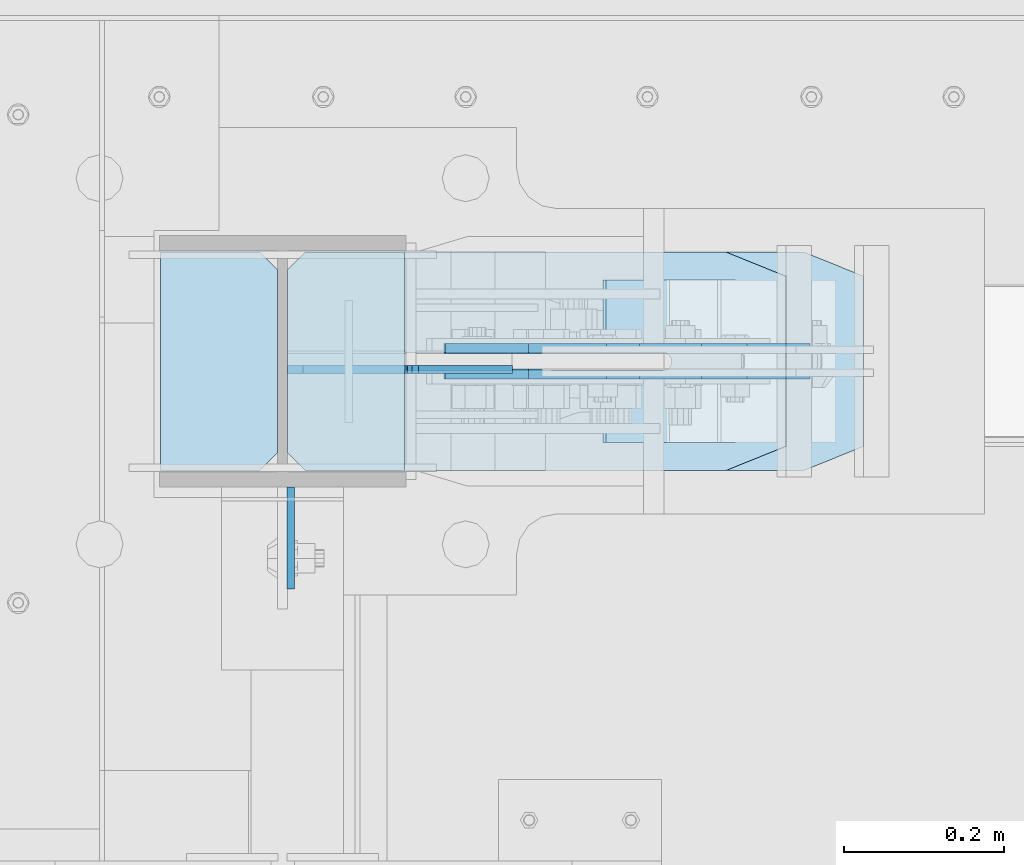
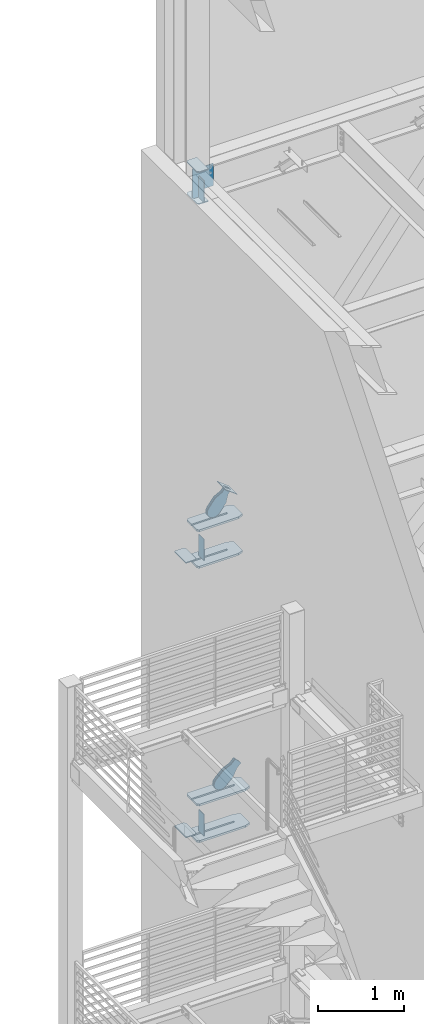
# One storey, part 1066 of 1179: 17 plates, 6 elements without a shape of their own.
"""IFC2X3 building model written with IfcOpenShell, lengths in millimetres."""

import ifcopenshell
import ifcopenshell.guid

model = None  # the IFC model being written
_history = None  # IfcOwnerHistory: only IFC2X3 demands one
_inside = {}  # id of a spatial element -> (the spatial element, [elements in it])
_under = {}  # id of a project, library or spatial element -> (it, [spatial elements below it])
_declared = {}  # id of a project -> (the project, [libraries it declares])
_typed = {}  # id of a type object -> (the type object, [elements of that type])
_made_of = {}  # id of a material, layer set ... -> (it, [elements and type objects made of it])


def new_model(schema):
    """Start an empty IFC model of exactly this schema.

    Asked for "IFC4X3", IfcOpenShell would pick the latest addendum, in which some entities
    have other attributes; the version numbers below select the first issue.
    IFC2X3 requires an IfcOwnerHistory on every rooted entity: one is made here for all.
    """
    global model, _history
    if schema == "IFC4X3":
        model = ifcopenshell.file(schema_version=(4, 3, 0, 0))
    else:
        model = ifcopenshell.file(schema=schema)
    _inside.clear()
    _under.clear()
    _declared.clear()
    _typed.clear()
    _made_of.clear()
    _history = None
    if model.schema == "IFC2X3":
        org = make("IfcOrganization", Name="unknown")
        user = make(
            "IfcPersonAndOrganization",
            ThePerson=make("IfcPerson", FamilyName="unknown"),
            TheOrganization=org,
        )
        app = make(
            "IfcApplication",
            ApplicationDeveloper=org,
            Version="unknown",
            ApplicationFullName="unknown",
            ApplicationIdentifier="unknown",
        )
        _history = make(
            "IfcOwnerHistory",
            OwningUser=user,
            OwningApplication=app,
            ChangeAction="ADDED",
            CreationDate=0,
        )
    return model


def make(cls, **values):
    """One entity of the class cls with the attributes given. An attribute that is None is left unset."""
    return model.create_entity(
        cls, **{name: value for name, value in values.items() if value is not None}
    )


def rooted(cls, **values):
    """An entity with a GlobalId (a new one), such as an element, a storey or a relation."""
    return make(cls, GlobalId=ifcopenshell.guid.new(), OwnerHistory=_history, **values)


def si_unit(unit_type, name, prefix=None):
    """IfcSIUnit, for example si_unit("LENGTHUNIT", "METRE", prefix="MILLI")."""
    return make("IfcSIUnit", UnitType=unit_type, Prefix=prefix, Name=name)


def assignment(units):
    """IfcUnitAssignment: the units of a project."""
    return None if units is None else make("IfcUnitAssignment", Units=units)


def point(xyz):
    """IfcCartesianPoint."""
    return None if xyz is None else make("IfcCartesianPoint", Coordinates=xyz)


def direction(xyz):
    """IfcDirection."""
    return None if xyz is None else make("IfcDirection", DirectionRatios=xyz)


def frame(location, z_axis=None, x_axis=None):
    """IfcAxis2Placement3D, a coordinate frame: its origin and axes. An axis left out is left unset."""
    return make(
        "IfcAxis2Placement3D",
        Location=point(location),
        Axis=direction(z_axis),
        RefDirection=direction(x_axis),
    )


def origin_with_axes():
    """The frame at (0, 0, 0) with the z axis (0, 0, 1) and the x axis (1, 0, 0) written out."""
    return frame((0.0, 0.0, 0.0), z_axis=(0.0, 0.0, 1.0), x_axis=(1.0, 0.0, 0.0))


def place(relative_to, where):
    """IfcLocalPlacement: puts the frame where relative to a parent placement (None: the world)."""
    return make(
        "IfcLocalPlacement", PlacementRelTo=relative_to, RelativePlacement=where
    )


def context(
    kind, dimensions, precision=None, world=None, true_north=None, identifier=None
):
    """IfcGeometricRepresentationContext, for example the 3D "Model" context."""
    return make(
        "IfcGeometricRepresentationContext",
        ContextIdentifier=identifier,
        ContextType=kind,
        CoordinateSpaceDimension=dimensions,
        Precision=precision,
        WorldCoordinateSystem=world,
        TrueNorth=true_north,
    )


def subcontext(parent, identifier, kind, view, scale=None):
    """IfcGeometricRepresentationSubContext, for example "Body" below "Model"."""
    return make(
        "IfcGeometricRepresentationSubContext",
        ContextIdentifier=identifier,
        ContextType=kind,
        ParentContext=parent,
        TargetScale=scale,
        TargetView=view,
    )


def project(units=None, contexts=None):
    """IfcProject with its units and contexts."""
    return rooted(
        "IfcProject",
        Name="project",
        RepresentationContexts=contexts,
        UnitsInContext=assignment(units),
    )


def spatial(cls, under=None, at=None, **own):
    """A site, building, storey or space (cls), placed at a placement, below another one or the project."""
    s = rooted(cls, ObjectPlacement=at, **own)
    if under is not None:
        _under.setdefault(under.id(), (under, []))[1].append(s)
    return s


def faces_of(points, faces, orient=None, outer=None):
    """IfcFace entities. A face is a list of loops; a loop is a list of indices into points, from 0.

    orient and outer hold one flag for each loop. By default every Orientation is true, the
    first loop of a face is its IfcFaceOuterBound and the others are IfcFaceBound.
    """
    made = []
    for i, loops in enumerate(faces):
        bounds = []
        for j, loop in enumerate(loops):
            is_outer = j == 0 if outer is None else outer[i][j]
            bounds.append(
                make(
                    "IfcFaceOuterBound" if is_outer else "IfcFaceBound",
                    Bound=make("IfcPolyLoop", Polygon=[points[k] for k in loop]),
                    Orientation=True if orient is None else orient[i][j],
                )
            )
        made.append(make("IfcFace", Bounds=bounds))
    return made


def faceted_brep(points, faces, orient=None, outer=None, voids=None):
    """IfcFacetedBrep: a solid bounded by flat faces; with voids (closed shells), ...WithVoids."""
    shared = [point(p) for p in points]
    hull = make("IfcClosedShell", CfsFaces=faces_of(shared, faces, orient, outer))
    if voids is None:
        return make("IfcFacetedBrep", Outer=hull)
    return make(
        "IfcFacetedBrepWithVoids",
        Outer=hull,
        Voids=[
            make(cls, CfsFaces=faces_of(shared, fs, o, b)) for cls, fs, o, b in voids
        ],
    )


def shape(context_of_items, identifier, shape_type, items):
    """IfcShapeRepresentation: the items that make up one representation, for example the "Body"."""
    return make(
        "IfcShapeRepresentation",
        ContextOfItems=context_of_items,
        RepresentationIdentifier=identifier,
        RepresentationType=shape_type,
        Items=items,
    )


def material(Name=None, Category=None):
    """IfcMaterial."""
    return make("IfcMaterial", Name=Name, Category=Category)


def made_of(thing, what):
    """Note that an element or type object is made of a material, layer set ...; save() writes the relation."""
    if what is not None:
        _made_of.setdefault(what.id(), (what, []))[1].append(thing)
    return thing


def type_object(cls, material=None, **own):
    """A type object (cls), such as IfcWallType, which elements share."""
    return made_of(rooted(cls, **own), material)


def element(
    cls,
    number,
    at=None,
    inside=None,
    cuts=None,
    type_object=None,
    material=None,
    context=None,
    identifier="Body",
    shape_type=None,
    held_by="IfcProductDefinitionShape",
    body=None,
    shapes=None,
    **own,
):
    """One element of the class cls, such as IfcWall. Its Tag is "e" and its number.

    at: its placement. inside: the storey or other place that contains it. cuts: it is an
    opening in that element (IfcRelVoidsElement). A single representation is given by context,
    identifier, shape_type and body (its items); several are given by shapes. held_by: the class
    of the entity that holds the representations. save() writes the other relations.
    """
    e = rooted(cls, Tag="e%d" % number, ObjectPlacement=at, **own)
    if body is not None:
        shapes = [shape(context, identifier, shape_type, body)]
    if shapes is not None:
        e.Representation = make(held_by, Representations=shapes)
    if inside is not None:
        _inside.setdefault(inside.id(), (inside, []))[1].append(e)
    if cuts is not None:
        rooted(
            "IfcRelVoidsElement", RelatingBuildingElement=cuts, RelatedOpeningElement=e
        )
    if type_object is not None:
        _typed.setdefault(type_object.id(), (type_object, []))[1].append(e)
    return made_of(e, material)


def aggregate(whole, parts):
    """IfcRelAggregates: a whole, such as a stair, and the parts it consists of."""
    return rooted("IfcRelAggregates", RelatingObject=whole, RelatedObjects=parts)


def save(model, path):
    """Write the relations noted so far, then the file.

    IfcRelAggregates (storeys below a building ...), IfcRelContainedInSpatialStructure (elements
    in a storey), IfcRelDefinesByType, IfcRelAssociatesMaterial and IfcRelDeclares: one each for
    every whole, place, type object, material and project.
    """
    for whole, parts in _under.values():
        aggregate(whole, parts)
    for where, things in _inside.values():
        rooted(
            "IfcRelContainedInSpatialStructure",
            RelatedElements=things,
            RelatingStructure=where,
        )
    for kind, things in _typed.values():
        rooted("IfcRelDefinesByType", RelatedObjects=things, RelatingType=kind)
    for what, things in _made_of.values():
        rooted("IfcRelAssociatesMaterial", RelatedObjects=things, RelatingMaterial=what)
    for by, libraries in _declared.values():
        rooted("IfcRelDeclares", RelatingContext=by, RelatedDefinitions=libraries)
    model.write(path)


model = new_model("IFC2X3")

# Units and contexts
model_context = context("Model", 3, precision=1e-05, world=origin_with_axes())
body_context = subcontext(model_context, "Body", "Model", "MODEL_VIEW")
ifc_project = project(units=[si_unit("LENGTHUNIT", "METRE", prefix="MILLI"), si_unit("AREAUNIT", "SQUARE_METRE"), si_unit("VOLUMEUNIT", "CUBIC_METRE"), si_unit("MASSUNIT", "GRAM", prefix="KILO"), si_unit("TIMEUNIT", "SECOND"), si_unit("PLANEANGLEUNIT", "RADIAN"), si_unit("SOLIDANGLEUNIT", "STERADIAN"), si_unit("THERMODYNAMICTEMPERATUREUNIT", "DEGREE_CELSIUS"), si_unit("LUMINOUSINTENSITYUNIT", "LUMEN")], contexts=[model_context])

# Site, building, storey
site_placement = place(None, origin_with_axes())
site = spatial("IfcSite", under=ifc_project, at=site_placement, CompositionType="ELEMENT")
building_placement = place(site_placement, origin_with_axes())
building = spatial("IfcBuilding", under=site, at=building_placement, Name="Undefined", CompositionType="ELEMENT")
storey_placement = place(building_placement, origin_with_axes())
storey = spatial("IfcBuildingStorey", under=building, at=storey_placement, Name="Undefined", CompositionType="ELEMENT", Elevation=0.0)

# Assembly, plates
assembly_1_placement = place(storey_placement, origin_with_axes())
assembly_1 = element("IfcElementAssembly", 1, at=assembly_1_placement, inside=storey, Name="COLUMN", AssemblyPlace="NOTDEFINED", PredefinedType="RIGID_FRAME")
ifc_material_1 = material(Name="STEEL/A36")
plate_type_1 = type_object("IfcPlateType", PredefinedType="NOTDEFINED")
plate_1_placement = place(assembly_1_placement, frame((442.11875, 41041.6375, 13081.0), z_axis=(0.0, -1.0, 0.0), x_axis=(0.0, 0.0, -1.0)))
plate_1 = element("IfcPlate", 2, at=plate_1_placement, type_object=plate_type_1, material=ifc_material_1, Name="PLATE", context=body_context, shape_type="Brep", body=[
    faceted_brep([(0.0, -4.76249999999709, 0.0), (0.0, -4.76249999999709, 127.0), (0.0, 4.76249999999709, 127.0), (0.0, 4.76249999999709, 0.0), (304.799999999999, -4.76249999999982, 127.0), (304.799999999999, 4.76249999999982, 127.0), (304.799987792969, -4.76250000000073, 0.0), (304.799987792969, 4.76250000000073, 0.0)], [[[0, 1, 2, 3]], [[2, 1, 4, 5]], [[4, 6, 7, 5]], [[6, 0, 3, 7]], [[5, 7, 3, 2]], [[6, 4, 1, 0]]]),
])
plate_2_placement = place(assembly_1_placement, frame((442.118750000001, 41041.6375, 7975.5999983942), z_axis=(0.0, -1.0, 0.0), x_axis=(0.0, 0.0, -1.0)))
plate_2 = element("IfcPlate", 3, at=plate_2_placement, type_object=plate_type_1, material=ifc_material_1, Name="PLATE", context=body_context, shape_type="Brep", body=[
    faceted_brep([(0.0, -4.76249999999709, 0.0), (0.0, -4.76249999999709, 127.0), (0.0, 4.76249999999709, 127.0), (0.0, 4.76249999999709, 0.0), (304.799999999999, -4.76249999999982, 127.0), (304.799999999999, 4.76249999999982, 127.0), (304.799987792969, -4.76250000000073, 0.0), (304.799987792969, 4.76250000000073, 0.0)], [[[0, 1, 2, 3]], [[2, 1, 4, 5]], [[4, 6, 7, 5]], [[6, 0, 3, 7]], [[5, 7, 3, 2]], [[6, 4, 1, 0]]]),
])
plate_3_placement = place(assembly_1_placement, frame((442.11875, 41041.6375, 4051.3), z_axis=(0.0, -1.0, 0.0), x_axis=(0.0, 0.0, -1.0)))
plate_3 = element("IfcPlate", 4, at=plate_3_placement, type_object=plate_type_1, material=ifc_material_1, Name="PLATE", context=body_context, shape_type="Brep", body=[
    faceted_brep([(0.0, -4.76249999999709, 0.0), (0.0, -4.76249999999709, 127.0), (0.0, 4.76249999999709, 127.0), (0.0, 4.76249999999709, 0.0), (304.799999999999, -4.76249999999982, 127.0), (304.799999999999, 4.76249999999982, 127.0), (304.799987792969, -4.76250000000073, 0.0), (304.799987792969, 4.76250000000073, 0.0)], [[[0, 1, 2, 3]], [[2, 1, 4, 5]], [[4, 6, 7, 5]], [[6, 0, 3, 7]], [[5, 7, 3, 2]], [[6, 4, 1, 0]]]),
])

# Assembly, plate
assembly_2_placement = place(storey_placement, origin_with_axes())
assembly_2 = element("IfcElementAssembly", 5, at=assembly_2_placement, inside=storey, Name="Plate", AssemblyPlace="NOTDEFINED", PredefinedType="RIGID_FRAME")
plate_type_2 = type_object("IfcPlateType", PredefinedType="NOTDEFINED")
plate_4_placement = place(assembly_2_placement, frame((995.235146671888, 41097.2, 8310.43822059521), z_axis=(-0.795206441873757, 0.0, 0.606338778903741), x_axis=(0.0, 1.0, 0.0)))
plate_4 = element("IfcPlate", 6, at=plate_4_placement, type_object=plate_type_2, material=ifc_material_1, Name="Plate", context=body_context, shape_type="Brep", body=[
    faceted_brep([(0.0, -3.17500000000109, 0.0), (0.0, -3.17500000000291, 203.200000000368), (0.0, 3.17499999998836, 203.200000000361), (0.0, 3.17500000000109, 7.27595761418343e-12), (203.199999999997, -3.17500000000291, 203.200000000368), (203.199999999997, 3.17499999998836, 203.200000000361), (203.199999999997, -3.17499999999927, 3.63797880709171e-12), (203.199999999997, 3.17499999999382, -3.63797880709171e-12)], [[[0, 1, 2, 3]], [[1, 4, 5, 2]], [[4, 6, 7, 5]], [[6, 0, 3, 7]], [[5, 7, 3, 2]], [[6, 4, 1, 0]]]),
])
aggregate(assembly_2, [plate_4])

# Plate
ifc_material_2 = material(Name="STEEL/A572-GR.50")
plate_type_3 = type_object("IfcPlateType", PredefinedType="NOTDEFINED")
plate_5_placement = place(assembly_1_placement, frame((1060.25983114869, 41335.1078456819, 7478.7125), z_axis=(0.0, -1.0, 0.0), x_axis=(-1.0, 0.0, 0.0)))
plate_5 = element("IfcPlate", 7, at=plate_5_placement, type_object=plate_type_3, material=ifc_material_2, Name="PLATE", context=body_context, shape_type="Brep", body=[
    faceted_brep([(0.0, -14.2875000000004, 30.1625003814697), (0.0, -14.2875000000004, 242.453264224023), (0.0, 14.2875000000004, 242.453264224023), (0.0, 14.2875000000004, 30.1625003814697), (74.6125030517578, -14.2875000000004, 272.615764605493), (74.6125030517578, 14.2875000000004, 272.615764605493), (599.884830625004, -14.2875000000004, 272.615764605493), (599.884830625004, 14.2875000000004, 272.615764605493), (622.109831006474, -14.2875000000004, 250.390764224023), (622.109831006474, 14.2875000000004, 250.390764224023), (622.109831006474, -14.2875000000004, 147.202764605485), (622.109831006474, 14.2875000000004, 147.202764605485), (153.997588991463, -14.2875000000004, 147.62774786006), (153.997588991463, 14.2875000000004, 147.62774786006), (149.741922132855, -14.2875000000004, 146.784756922243), (149.741922132855, 14.2875000000004, 146.784756922243), (146.133343781504, -14.2875000000004, 144.376542559927), (146.133343781504, 14.2875000000004, 144.376542559927), (143.721854306888, -14.2875000000004, 140.770152031087), (143.721854306888, 14.2875000000004, 140.770152031087), (142.875000142223, -14.2875000000004, 136.525345872607), (142.875000142223, 14.2875000000004, 136.525345872607), (143.720888851711, -14.2875000000004, 132.272776157457), (143.720888851711, 14.2875000000004, 132.272776157457), (146.129776092153, -14.2875000000004, 128.667621631801), (146.129776092153, 14.2875000000004, 128.667621631801), (149.734930617809, -14.2875000000004, 126.258734391362), (149.734930617809, 14.2875000000004, 126.258734391362), (153.987500332958, -14.2875000000004, 125.412845681873), (153.987500332958, 14.2875000000004, 125.412845681873), (622.109831148695, -14.2875000000004, 125.412845681873), (622.109831148695, 14.2875000000004, 125.412845681873), (622.109831031677, -14.2875000000004, 22.2250003814697), (622.109831031677, 14.2875000000004, 22.2250003814697), (599.884830625004, -14.2875000000004, 0.0), (599.884830625004, 14.2875000000004, 0.0), (74.6125030517578, -14.2875000000004, 0.0), (74.6125030517578, 14.2875000000004, 0.0)], [[[0, 1, 2, 3]], [[1, 4, 5, 2]], [[4, 6, 7, 5]], [[6, 8, 9, 7]], [[8, 10, 11, 9]], [[10, 12, 13, 11]], [[12, 14, 15, 13]], [[14, 16, 17, 15]], [[16, 18, 19, 17]], [[18, 20, 21, 19]], [[20, 22, 23, 21]], [[22, 24, 25, 23]], [[24, 26, 27, 25]], [[26, 28, 29, 27]], [[28, 30, 31, 29]], [[30, 32, 33, 31]], [[32, 34, 35, 33]], [[34, 36, 37, 35]], [[36, 0, 3, 37]], [[5, 7, 9, 11, 13, 15, 17, 19, 21, 23, 25, 27, 29, 31, 33, 35, 37, 3, 2]], [[36, 34, 32, 30, 28, 26, 24, 22, 20, 18, 16, 14, 12, 10, 8, 6, 4, 1, 0]]]),
])

plate_6_placement = place(assembly_1_placement, frame((1060.25983114869, 41335.1078456819, 7999.4125), z_axis=(0.0, -1.0, 0.0), x_axis=(-1.0, 0.0, 0.0)))
plate_6 = element("IfcPlate", 8, at=plate_6_placement, type_object=plate_type_3, material=ifc_material_2, Name="PLATE", context=body_context, shape_type="Brep", body=[
    faceted_brep([(0.0, -14.2875000000004, 30.1625003814697), (0.0, -14.2875000000004, 242.453264224023), (0.0, 14.2875000000004, 242.453264224023), (0.0, 14.2875000000004, 30.1625003814697), (74.6125030517578, -14.2875000000004, 272.615764605493), (74.6125030517578, 14.2875000000004, 272.615764605493), (599.884830625004, -14.2875000000004, 272.615764605493), (599.884830625004, 14.2875000000004, 272.615764605493), (622.109831006474, -14.2875000000004, 250.390764224023), (622.109831006474, 14.2875000000004, 250.390764224023), (622.109831006474, -14.2875000000004, 147.202764605485), (622.109831006474, 14.2875000000004, 147.202764605485), (153.997588991463, -14.2875000000004, 147.62774786006), (153.997588991463, 14.2875000000004, 147.62774786006), (149.741922132855, -14.2875000000004, 146.784756922243), (149.741922132855, 14.2875000000004, 146.784756922243), (146.133343781504, -14.2875000000004, 144.376542559927), (146.133343781504, 14.2875000000004, 144.376542559927), (143.721854306888, -14.2875000000004, 140.770152031087), (143.721854306888, 14.2875000000004, 140.770152031087), (142.875000142223, -14.2875000000004, 136.525345872607), (142.875000142223, 14.2875000000004, 136.525345872607), (143.720888851711, -14.2875000000004, 132.272776157457), (143.720888851711, 14.2875000000004, 132.272776157457), (146.129776092153, -14.2875000000004, 128.667621631801), (146.129776092153, 14.2875000000004, 128.667621631801), (149.734930617809, -14.2875000000004, 126.258734391362), (149.734930617809, 14.2875000000004, 126.258734391362), (153.987500332958, -14.2875000000004, 125.412845681873), (153.987500332958, 14.2875000000004, 125.412845681873), (622.109831148695, -14.2875000000004, 125.412845681873), (622.109831148695, 14.2875000000004, 125.412845681873), (622.109831031677, -14.2875000000004, 22.2250003814697), (622.109831031677, 14.2875000000004, 22.2250003814697), (599.884830625004, -14.2875000000004, 0.0), (599.884830625004, 14.2875000000004, 0.0), (74.6125030517578, -14.2875000000004, 0.0), (74.6125030517578, 14.2875000000004, 0.0)], [[[0, 1, 2, 3]], [[1, 4, 5, 2]], [[4, 6, 7, 5]], [[6, 8, 9, 7]], [[8, 10, 11, 9]], [[10, 12, 13, 11]], [[12, 14, 15, 13]], [[14, 16, 17, 15]], [[16, 18, 19, 17]], [[18, 20, 21, 19]], [[20, 22, 23, 21]], [[22, 24, 25, 23]], [[24, 26, 27, 25]], [[26, 28, 29, 27]], [[28, 30, 31, 29]], [[30, 32, 33, 31]], [[32, 34, 35, 33]], [[34, 36, 37, 35]], [[36, 0, 3, 37]], [[5, 7, 9, 11, 13, 15, 17, 19, 21, 23, 25, 27, 29, 31, 33, 35, 37, 3, 2]], [[36, 34, 32, 30, 28, 26, 24, 22, 20, 18, 16, 14, 12, 10, 8, 6, 4, 1, 0]]]),
])

plate_7_placement = place(assembly_1_placement, frame((1157.0931525714, 41335.325, 3567.1125), z_axis=(0.0, -1.0, 0.0), x_axis=(-1.0, 0.0, 0.0)))
plate_7 = element("IfcPlate", 9, at=plate_7_placement, type_object=plate_type_3, material=ifc_material_2, Name="PLATE", context=body_context, shape_type="Brep", body=[
    faceted_brep([(0.0, -14.2875000000004, 30.1625003814697), (0.0, -14.2874999999999, 242.887505722043), (0.0, 14.2874999999999, 242.887505722043), (0.0, 14.2875000000004, 30.1625003814697), (74.6125030517578, -14.2874999999999, 273.050006103513), (74.6125030517578, 14.2874999999999, 273.050006103513), (696.718152189929, -14.2874999999999, 273.050006103513), (696.718152189929, 14.2874999999999, 273.050006103513), (718.943152571399, -14.2874999999999, 250.825005722043), (718.943152571399, 14.2874999999999, 250.825005722043), (718.943152571399, -14.2874999999999, 147.637499999997), (718.943152571399, 14.2874999999999, 147.637499999997), (153.987500190735, -14.2874999999999, 147.637500000004), (153.987500190735, 14.2874999999999, 147.637500000004), (149.734930475587, -14.2874999999999, 146.791611290508), (149.734930475587, 14.2874999999999, 146.791611290508), (146.129775949929, -14.2874999999999, 144.382724050069), (146.129775949929, 14.2874999999999, 144.382724050069), (143.720888709488, -14.2874999999999, 140.777569524413), (143.720888709488, 14.2874999999999, 140.777569524413), (142.875, -14.2874999999999, 136.525000190733), (142.875, 14.2874999999999, 136.525000190733), (143.720888709488, -14.2874999999999, 132.272430475583), (143.720888709488, 14.2874999999999, 132.272430475583), (146.129775949929, -14.2874999999999, 128.667275949927), (146.129775949929, 14.2874999999999, 128.667275949927), (149.734930475587, -14.2874999999999, 126.258388709488), (149.734930475587, 14.2874999999999, 126.258388709488), (153.987500190735, -14.2874999999999, 125.412499999999), (153.987500190735, 14.2874999999999, 125.412499999999), (718.943152571399, -14.2874999999999, 125.412499999999), (718.943152571399, 14.2874999999999, 125.412499999999), (718.943152571399, -14.2874999999999, 22.2250003814697), (718.943152571399, 14.2874999999999, 22.2250003814697), (696.718152189929, -14.2874999999999, 0.0), (696.718152189929, 14.2874999999999, 0.0), (74.6125030517578, -14.2875000000004, 0.0), (74.6125030517578, 14.2875000000004, 0.0)], [[[0, 1, 2, 3]], [[1, 4, 5, 2]], [[4, 6, 7, 5]], [[6, 8, 9, 7]], [[8, 10, 11, 9]], [[10, 12, 13, 11]], [[12, 14, 15, 13]], [[14, 16, 17, 15]], [[16, 18, 19, 17]], [[18, 20, 21, 19]], [[20, 22, 23, 21]], [[22, 24, 25, 23]], [[24, 26, 27, 25]], [[26, 28, 29, 27]], [[28, 30, 31, 29]], [[30, 32, 33, 31]], [[32, 34, 35, 33]], [[34, 36, 37, 35]], [[36, 0, 3, 37]], [[5, 7, 9, 11, 13, 15, 17, 19, 21, 23, 25, 27, 29, 31, 33, 35, 37, 3, 2]], [[36, 34, 32, 30, 28, 26, 24, 22, 20, 18, 16, 14, 12, 10, 8, 6, 4, 1, 0]]]),
])

plate_8_placement = place(assembly_1_placement, frame((1157.0931525714, 41335.325, 4087.8125), z_axis=(0.0, -1.0, 0.0), x_axis=(-1.0, 0.0, 0.0)))
plate_8 = element("IfcPlate", 10, at=plate_8_placement, type_object=plate_type_3, material=ifc_material_2, Name="PLATE", context=body_context, shape_type="Brep", body=[
    faceted_brep([(0.0, -14.2875000000004, 30.1625003814697), (0.0, -14.2874999999999, 242.887505722043), (0.0, 14.2874999999999, 242.887505722043), (0.0, 14.2875000000004, 30.1625003814697), (74.6125030517578, -14.2874999999999, 273.050006103513), (74.6125030517578, 14.2874999999999, 273.050006103513), (696.718152189929, -14.2874999999999, 273.050006103513), (696.718152189929, 14.2874999999999, 273.050006103513), (718.943152571399, -14.2874999999999, 250.825005722043), (718.943152571399, 14.2874999999999, 250.825005722043), (718.943152571399, -14.2874999999999, 147.637499999997), (718.943152571399, 14.2874999999999, 147.637499999997), (153.987500190735, -14.2874999999999, 147.637500000004), (153.987500190735, 14.2874999999999, 147.637500000004), (149.734930475587, -14.2874999999999, 146.791611290508), (149.734930475587, 14.2874999999999, 146.791611290508), (146.129775949929, -14.2874999999999, 144.382724050069), (146.129775949929, 14.2874999999999, 144.382724050069), (143.720888709488, -14.2874999999999, 140.777569524413), (143.720888709488, 14.2874999999999, 140.777569524413), (142.875, -14.2874999999999, 136.525000190733), (142.875, 14.2874999999999, 136.525000190733), (143.720888709488, -14.2874999999999, 132.272430475583), (143.720888709488, 14.2874999999999, 132.272430475583), (146.129775949929, -14.2874999999999, 128.667275949927), (146.129775949929, 14.2874999999999, 128.667275949927), (149.734930475587, -14.2874999999999, 126.258388709488), (149.734930475587, 14.2874999999999, 126.258388709488), (153.987500190735, -14.2874999999999, 125.412499999999), (153.987500190735, 14.2874999999999, 125.412499999999), (718.943152571399, -14.2874999999999, 125.412499999999), (718.943152571399, 14.2874999999999, 125.412499999999), (718.943152571399, -14.2874999999999, 22.2250003814697), (718.943152571399, 14.2874999999999, 22.2250003814697), (696.718152189929, -14.2874999999999, 0.0), (696.718152189929, 14.2874999999999, 0.0), (74.6125030517578, -14.2875000000004, 0.0), (74.6125030517578, 14.2875000000004, 0.0)], [[[0, 1, 2, 3]], [[1, 4, 5, 2]], [[4, 6, 7, 5]], [[6, 8, 9, 7]], [[8, 10, 11, 9]], [[10, 12, 13, 11]], [[12, 14, 15, 13]], [[14, 16, 17, 15]], [[16, 18, 19, 17]], [[18, 20, 21, 19]], [[20, 22, 23, 21]], [[22, 24, 25, 23]], [[24, 26, 27, 25]], [[26, 28, 29, 27]], [[28, 30, 31, 29]], [[30, 32, 33, 31]], [[32, 34, 35, 33]], [[34, 36, 37, 35]], [[36, 0, 3, 37]], [[5, 7, 9, 11, 13, 15, 17, 19, 21, 23, 25, 27, 29, 31, 33, 35, 37, 3, 2]], [[36, 34, 32, 30, 28, 26, 24, 22, 20, 18, 16, 14, 12, 10, 8, 6, 4, 1, 0]]]),
])

plate_type_4 = type_object("IfcPlateType", PredefinedType="NOTDEFINED")
plate_9_placement = place(assembly_1_placement, frame((584.2, 41062.275, 12658.725), z_axis=(0.0, 1.0, 0.0), x_axis=(-1.0, 0.0, 0.0)))
plate_9 = element("IfcPlate", 11, at=plate_9_placement, type_object=plate_type_4, material=ifc_material_1, Name="PLATE", context=body_context, shape_type="Brep", body=[
    faceted_brep([(0.0, -6.34999999999854, 0.0), (0.0, -6.34999999999991, 273.05), (0.0, 6.34999999999991, 273.05), (0.0, 6.34999999999854, 0.0), (123.824999618599, -6.34999999999991, 273.05), (123.824999618599, 6.34999999999991, 273.05), (146.050000000068, -6.34999999999991, 250.82499961853), (146.050000000068, 6.34999999999991, 250.82499961853), (146.050000000068, -6.34999999999991, 22.2250003814697), (146.050000000068, 6.34999999999991, 22.2250003814697), (123.824999618599, -6.34999999999991, 0.0), (123.824999618599, 6.34999999999991, 0.0)], [[[0, 1, 2, 3]], [[1, 4, 5, 2]], [[4, 6, 7, 5]], [[6, 8, 9, 7]], [[8, 10, 11, 9]], [[10, 0, 3, 11]], [[5, 7, 9, 11, 3, 2]], [[10, 8, 6, 4, 1, 0]]]),
])

plate_10_placement = place(assembly_1_placement, frame((584.2, 41062.275, 13112.75), z_axis=(0.0, 1.0, 0.0), x_axis=(-1.0, 0.0, 0.0)))
plate_10 = element("IfcPlate", 12, at=plate_10_placement, type_object=plate_type_4, material=ifc_material_1, Name="PLATE", context=body_context, shape_type="Brep", body=[
    faceted_brep([(0.0, -6.34999999999854, 0.0), (0.0, -6.34999999999991, 273.05), (0.0, 6.34999999999991, 273.05), (0.0, 6.34999999999854, 0.0), (123.824999618599, -6.34999999999991, 273.05), (123.824999618599, 6.34999999999991, 273.05), (146.050000000068, -6.34999999999991, 250.82499961853), (146.050000000068, 6.34999999999991, 250.82499961853), (146.050000000068, -6.34999999999991, 22.2250003814697), (146.050000000068, 6.34999999999991, 22.2250003814697), (123.824999618599, -6.34999999999991, 0.0), (123.824999618599, 6.34999999999991, 0.0)], [[[0, 1, 2, 3]], [[1, 4, 5, 2]], [[4, 6, 7, 5]], [[6, 8, 9, 7]], [[8, 10, 11, 9]], [[10, 0, 3, 11]], [[5, 7, 9, 11, 3, 2]], [[10, 8, 6, 4, 1, 0]]]),
])

plate_11_placement = place(assembly_1_placement, frame((279.4, 41335.325, 7604.125), z_axis=(0.0, -1.0, 0.0), x_axis=(1.0, 0.0, 0.0)))
plate_11 = element("IfcPlate", 13, at=plate_11_placement, type_object=plate_type_4, material=ifc_material_1, Name="PLATE", context=body_context, shape_type="Brep", body=[
    faceted_brep([(0.0, -6.34999999999854, 0.0), (0.0, -6.34999999999991, 273.05), (0.0, 6.34999999999991, 273.05), (0.0, 6.34999999999854, 0.0), (123.824999618599, -6.34999999999991, 273.05), (123.824999618599, 6.34999999999991, 273.05), (146.050000000068, -6.34999999999991, 250.82499961853), (146.050000000068, 6.34999999999991, 250.82499961853), (146.050000000068, -6.34999999999991, 22.2250003814697), (146.050000000068, 6.34999999999991, 22.2250003814697), (123.824999618599, -6.34999999999991, 0.0), (123.824999618599, 6.34999999999991, 0.0)], [[[0, 1, 2, 3]], [[1, 4, 5, 2]], [[4, 6, 7, 5]], [[6, 8, 9, 7]], [[8, 10, 11, 9]], [[10, 0, 3, 11]], [[5, 7, 9, 11, 3, 2]], [[10, 8, 6, 4, 1, 0]]]),
])

plate_12_placement = place(assembly_1_placement, frame((425.45, 41062.275, 3689.35), z_axis=(0.0, 1.0, 0.0), x_axis=(-1.0, 0.0, 0.0)))
plate_12 = element("IfcPlate", 14, at=plate_12_placement, type_object=plate_type_4, material=ifc_material_1, Name="PLATE", context=body_context, shape_type="Brep", body=[
    faceted_brep([(0.0, -6.34999999999854, 22.2250003814697), (0.0, -6.35000000000036, 250.82499961853), (0.0, 6.35000000000036, 250.82499961853), (0.0, 6.34999999999854, 22.2250003814697), (22.2250003814697, -6.35000000000036, 273.05), (22.2250003814697, 6.35000000000036, 273.05), (146.050003051758, -6.35000000000036, 273.049987792969), (146.050003051758, 6.35000000000036, 273.049987792969), (146.050003051758, -6.35000000000036, 0.0), (146.050003051758, 6.35000000000036, 0.0), (22.2250003814697, -6.34999999999854, 0.0), (22.2250003814697, 6.34999999999854, 0.0)], [[[0, 1, 2, 3]], [[1, 4, 5, 2]], [[4, 6, 7, 5]], [[6, 8, 9, 7]], [[8, 10, 11, 9]], [[10, 0, 3, 11]], [[5, 7, 9, 11, 3, 2]], [[10, 8, 6, 4, 1, 0]]]),
])

# Assembly, plate
assembly_3_placement = place(storey_placement, origin_with_axes())
assembly_3 = element("IfcElementAssembly", 15, at=assembly_3_placement, inside=storey, AssemblyPlace="NOTDEFINED", PredefinedType="RIGID_FRAME")
plate_type_5 = type_object("IfcPlateType", PredefinedType="NOTDEFINED")
plate_13_placement = place(assembly_3_placement, frame((913.41317482283, 41214.675, 8290.57776088241), z_axis=(-0.795206441873757, 0.0, 0.606338778903741), x_axis=(0.606338778903741, 0.0, 0.795206441873757)))
plate_13 = element("IfcPlate", 16, at=plate_13_placement, type_object=plate_type_5, material=ifc_material_1, context=body_context, shape_type="Brep", body=[
    faceted_brep([(0.0, -6.34999999999854, 0.0), (-101.600000000007, -6.34999999999854, -45.085691726028), (-101.600000000007, 6.34999999999854, -45.085691726028), (0.0, 6.34999999999854, 0.0), (-245.369242322517, -6.34999999999854, -45.085691725908), (-245.369242322517, 6.34999999999854, -45.085691725908), (-281.212328722571, -6.34999999999854, -37.9560585558283), (-281.212328722571, 6.34999999999854, -37.9560585558283), (-311.598630136563, -6.34999999999854, -17.6525810655148), (-311.598630136563, 6.34999999999854, -17.6525810655148), (-331.902107626699, -6.34999999999854, 12.7337203485949), (-331.902107626699, 6.34999999999854, 12.7337203485949), (-339.031740796561, -6.34999999999854, 48.5768098006738), (-339.031740796561, 6.34999999999854, 48.5768098006738), (-331.902107626408, -6.34999999999854, 84.4198962005139), (-331.902107626408, 6.34999999999854, 84.4198962005139), (-311.598630136172, -6.34999999999854, 114.806197614322), (-311.598630136172, 6.34999999999854, 114.806197614322), (-281.212328722244, -6.34999999999854, 135.109675104381), (-281.212328722244, 6.34999999999854, 135.109675104381), (-245.369240796288, -6.34999999999854, 142.239308274318), (-245.369240796288, 6.34999999999854, 142.239308274318), (-101.599999999052, -6.34999999999854, 142.239308274202), (-101.599999999052, 6.34999999999854, 142.239308274202), (4.938556230627e-10, -6.34999999999854, 97.1536165479993), (4.938556230627e-10, 6.34999999999854, 97.1536165479993), (68.5800000003655, -6.34999999999854, 97.153616547841), (68.5800000003655, 6.34999999999854, 97.153616547841), (68.5800000000518, -6.34999999999854, -9.09494701772928e-12), (68.5800000000518, 6.34999999999854, -9.09494701772928e-12)], [[[0, 1, 2, 3]], [[1, 4, 5, 2]], [[4, 6, 7, 5]], [[6, 8, 9, 7]], [[8, 10, 11, 9]], [[10, 12, 13, 11]], [[12, 14, 15, 13]], [[14, 16, 17, 15]], [[16, 18, 19, 17]], [[18, 20, 21, 19]], [[20, 22, 23, 21]], [[22, 24, 25, 23]], [[24, 26, 27, 25]], [[26, 28, 29, 27]], [[28, 0, 3, 29]], [[5, 7, 9, 11, 13, 15, 17, 19, 21, 23, 25, 27, 29, 3, 2]], [[28, 26, 24, 22, 20, 18, 16, 14, 12, 10, 8, 6, 4, 1, 0]]]),
])
aggregate(assembly_3, [plate_13])

assembly_4_placement = place(storey_placement, origin_with_axes())
assembly_4 = element("IfcElementAssembly", 17, at=assembly_4_placement, inside=storey, AssemblyPlace="NOTDEFINED", PredefinedType="RIGID_FRAME")
plate_14_placement = place(assembly_4_placement, frame((913.41317482283, 41182.925, 8290.57776088241), z_axis=(-0.795206441873757, 0.0, 0.606338778903741), x_axis=(0.606338778903741, 0.0, 0.795206441873757)))
plate_14 = element("IfcPlate", 18, at=plate_14_placement, type_object=plate_type_5, material=ifc_material_1, context=body_context, shape_type="Brep", body=[
    faceted_brep([(0.0, -6.34999999999854, 0.0), (-101.600000000007, -6.34999999999854, -45.085691726028), (-101.600000000007, 6.34999999999854, -45.085691726028), (0.0, 6.34999999999854, 0.0), (-245.369242322517, -6.34999999999854, -45.085691725908), (-245.369242322517, 6.34999999999854, -45.085691725908), (-281.212328722571, -6.34999999999854, -37.9560585558283), (-281.212328722571, 6.34999999999854, -37.9560585558283), (-311.598630136563, -6.34999999999854, -17.6525810655148), (-311.598630136563, 6.34999999999854, -17.6525810655148), (-331.902107626699, -6.34999999999854, 12.7337203485949), (-331.902107626699, 6.34999999999854, 12.7337203485949), (-339.031740796561, -6.34999999999854, 48.5768098006738), (-339.031740796561, 6.34999999999854, 48.5768098006738), (-331.902107626408, -6.34999999999854, 84.4198962005139), (-331.902107626408, 6.34999999999854, 84.4198962005139), (-311.598630136172, -6.34999999999854, 114.806197614322), (-311.598630136172, 6.34999999999854, 114.806197614322), (-281.212328722244, -6.34999999999854, 135.109675104381), (-281.212328722244, 6.34999999999854, 135.109675104381), (-245.369240796288, -6.34999999999854, 142.239308274318), (-245.369240796288, 6.34999999999854, 142.239308274318), (-101.599999999052, -6.34999999999854, 142.239308274202), (-101.599999999052, 6.34999999999854, 142.239308274202), (4.938556230627e-10, -6.34999999999854, 97.1536165479993), (4.938556230627e-10, 6.34999999999854, 97.1536165479993), (68.5800000003655, -6.34999999999854, 97.153616547841), (68.5800000003655, 6.34999999999854, 97.153616547841), (68.5800000000518, -6.34999999999854, -9.09494701772928e-12), (68.5800000000518, 6.34999999999854, -9.09494701772928e-12)], [[[0, 1, 2, 3]], [[1, 4, 5, 2]], [[4, 6, 7, 5]], [[6, 8, 9, 7]], [[8, 10, 11, 9]], [[10, 12, 13, 11]], [[12, 14, 15, 13]], [[14, 16, 17, 15]], [[16, 18, 19, 17]], [[18, 20, 21, 19]], [[20, 22, 23, 21]], [[22, 24, 25, 23]], [[24, 26, 27, 25]], [[26, 28, 29, 27]], [[28, 0, 3, 29]], [[5, 7, 9, 11, 13, 15, 17, 19, 21, 23, 25, 27, 29, 3, 2]], [[28, 26, 24, 22, 20, 18, 16, 14, 12, 10, 8, 6, 4, 1, 0]]]),
])
aggregate(assembly_4, [plate_14])

assembly_5_placement = place(storey_placement, origin_with_axes())
assembly_5 = element("IfcElementAssembly", 19, at=assembly_5_placement, inside=storey, AssemblyPlace="NOTDEFINED", PredefinedType="RIGID_FRAME")
plate_15_placement = place(assembly_5_placement, frame((1032.19723078425, 41214.675, 4346.71822898327), z_axis=(-0.705959813968941, 0.0, 0.708251890968841), x_axis=(0.70825189096884, 0.0, 0.705959813968941)))
plate_15 = element("IfcPlate", 20, at=plate_15_placement, type_object=plate_type_5, material=ifc_material_1, context=body_context, shape_type="Brep", body=[
    faceted_brep([(0.0, -6.34999999999854, 0.0), (-101.599999999963, -6.34999999999854, -37.5700345970108), (-101.599999999963, 6.34999999999854, -37.5700345970108), (0.0, 6.34999999999854, 0.0), (-245.369242323884, -6.34999999999854, -37.5700345970945), (-245.369242323884, 6.34999999999854, -37.5700345970945), (-281.212328723803, -6.34999999999854, -30.4404014271258), (-281.212328723803, 6.34999999999854, -30.4404014271258), (-311.598630137756, -6.34999999999854, -10.1369239370142), (-311.598630137756, 6.34999999999854, -10.1369239370142), (-331.902107627997, -6.34999999999854, 20.24937747687), (-331.902107627997, 6.34999999999854, 20.24937747687), (-339.031740798124, -6.34999999999854, 56.0924669287269), (-339.031740798124, 6.34999999999854, 56.0924669287269), (-331.902107628228, -6.34999999999854, 91.9355533287926), (-331.902107628228, 6.34999999999854, 91.9355533287926), (-311.598630138099, -6.34999999999854, 122.321854742866), (-311.598630138099, 6.34999999999854, 122.321854742866), (-281.212328724136, -6.34999999999854, 142.625332233139), (-281.212328724136, 6.34999999999854, 142.625332233139), (-245.36924079839, -6.34999999999854, 149.754965403199), (-245.36924079839, 6.34999999999854, 149.754965403199), (-101.600000000685, -6.34999999999854, 149.75496540329), (-101.600000000685, 6.34999999999854, 149.75496540329), (-4.35647962149233e-10, -6.34999999999854, 112.184930806416), (-4.35647962149233e-10, 6.34999999999854, 112.184930806416), (82.5499999996491, -6.34999999999854, 112.184930806461), (82.5499999996491, 6.34999999999854, 112.184930806461), (82.550000000203, -6.34999999999854, 1.2732925824821e-10), (82.550000000203, 6.34999999999854, 1.2732925824821e-10)], [[[0, 1, 2, 3]], [[1, 4, 5, 2]], [[4, 6, 7, 5]], [[6, 8, 9, 7]], [[8, 10, 11, 9]], [[10, 12, 13, 11]], [[12, 14, 15, 13]], [[14, 16, 17, 15]], [[16, 18, 19, 17]], [[18, 20, 21, 19]], [[20, 22, 23, 21]], [[22, 24, 25, 23]], [[24, 26, 27, 25]], [[26, 28, 29, 27]], [[28, 0, 3, 29]], [[5, 7, 9, 11, 13, 15, 17, 19, 21, 23, 25, 27, 29, 3, 2]], [[28, 26, 24, 22, 20, 18, 16, 14, 12, 10, 8, 6, 4, 1, 0]]]),
])
aggregate(assembly_5, [plate_15])

assembly_6_placement = place(storey_placement, origin_with_axes())
assembly_6 = element("IfcElementAssembly", 21, at=assembly_6_placement, inside=storey, AssemblyPlace="NOTDEFINED", PredefinedType="RIGID_FRAME")
plate_16_placement = place(assembly_6_placement, frame((1032.19723078425, 41182.925, 4346.71822898327), z_axis=(-0.705959813968941, 0.0, 0.708251890968841), x_axis=(0.70825189096884, 0.0, 0.705959813968941)))
plate_16 = element("IfcPlate", 22, at=plate_16_placement, type_object=plate_type_5, material=ifc_material_1, context=body_context, shape_type="Brep", body=[
    faceted_brep([(0.0, -6.34999999999854, 0.0), (-101.599999999963, -6.34999999999854, -37.5700345970108), (-101.599999999963, 6.34999999999854, -37.5700345970108), (0.0, 6.34999999999854, 0.0), (-245.369242323884, -6.34999999999854, -37.5700345970945), (-245.369242323884, 6.34999999999854, -37.5700345970945), (-281.212328723803, -6.34999999999854, -30.4404014271258), (-281.212328723803, 6.34999999999854, -30.4404014271258), (-311.598630137756, -6.34999999999854, -10.1369239370142), (-311.598630137756, 6.34999999999854, -10.1369239370142), (-331.902107627997, -6.34999999999854, 20.24937747687), (-331.902107627997, 6.34999999999854, 20.24937747687), (-339.031740798124, -6.34999999999854, 56.0924669287269), (-339.031740798124, 6.34999999999854, 56.0924669287269), (-331.902107628228, -6.34999999999854, 91.9355533287926), (-331.902107628228, 6.34999999999854, 91.9355533287926), (-311.598630138099, -6.34999999999854, 122.321854742866), (-311.598630138099, 6.34999999999854, 122.321854742866), (-281.212328724136, -6.34999999999854, 142.625332233139), (-281.212328724136, 6.34999999999854, 142.625332233139), (-245.36924079839, -6.34999999999854, 149.754965403199), (-245.36924079839, 6.34999999999854, 149.754965403199), (-101.600000000685, -6.34999999999854, 149.75496540329), (-101.600000000685, 6.34999999999854, 149.75496540329), (-4.35647962149233e-10, -6.34999999999854, 112.184930806416), (-4.35647962149233e-10, 6.34999999999854, 112.184930806416), (82.5499999996491, -6.34999999999854, 112.184930806461), (82.5499999996491, 6.34999999999854, 112.184930806461), (82.550000000203, -6.34999999999854, 1.2732925824821e-10), (82.550000000203, 6.34999999999854, 1.2732925824821e-10)], [[[0, 1, 2, 3]], [[1, 4, 5, 2]], [[4, 6, 7, 5]], [[6, 8, 9, 7]], [[8, 10, 11, 9]], [[10, 12, 13, 11]], [[12, 14, 15, 13]], [[14, 16, 17, 15]], [[16, 18, 19, 17]], [[18, 20, 21, 19]], [[20, 22, 23, 21]], [[22, 24, 25, 23]], [[24, 26, 27, 25]], [[26, 28, 29, 27]], [[28, 0, 3, 29]], [[5, 7, 9, 11, 13, 15, 17, 19, 21, 23, 25, 27, 29, 3, 2]], [[28, 26, 24, 22, 20, 18, 16, 14, 12, 10, 8, 6, 4, 1, 0]]]),
])
aggregate(assembly_6, [plate_16])

# Plate
plate_type_6 = type_object("IfcPlateType", PredefinedType="NOTDEFINED")
plate_17_placement = place(assembly_1_placement, frame((438.15, 41188.48125, 12684.125), z_axis=(0.707106781186573, 0.0, 0.707106781186522), x_axis=(0.707106781186522, 0.0, -0.707106781186573)))
plate_17 = element("IfcPlate", 23, at=plate_17_placement, type_object=plate_type_6, material=ifc_material_1, Name="PLATE", context=body_context, shape_type="Brep", body=[
    faceted_brep([(0.0, -4.76249999999709, 0.0), (-285.12313184404, -4.76249999999709, 285.12313184404), (-285.12313184404, 4.76249999999709, 285.12313184404), (0.0, 4.76249999999709, 0.0), (-285.123131844106, -4.76249999999709, 312.063900207191), (-285.123131844106, 4.76249999999709, 312.063900207191), (-194.198038626213, -4.76249999999709, 402.988993425091), (-194.198038626213, 4.76249999999709, 402.988993425091), (-189.707910295945, -4.76249999999709, 398.498865094823), (-189.707910295945, 4.76249999999709, 398.498865094823), (-181.467557359634, -4.76249999999709, 392.992837293867), (-181.467557359634, 4.76249999999709, 392.992837293867), (-171.747398323543, -4.76249999999709, 391.059377448692), (-171.747398323543, 4.76249999999709, 391.059377448692), (-162.02723928745, -4.76249999999709, 392.992837293865), (-162.02723928745, 4.76249999999709, 392.992837293865), (-153.786886351143, -4.76249999999709, 398.498865094822), (-153.786886351143, 4.76249999999709, 398.498865094822), (-77.4547090443302, -4.76249999999709, 474.831042401636), (-77.4547090443302, 4.76249999999709, 474.831042401636), (147.051693982479, -4.76249999999709, 250.324639374838), (147.051693982479, 4.76249999999709, 250.324639374838), (70.7195166756665, -4.76249999999709, 173.992462068023), (70.7195166756665, 4.76249999999709, 173.992462068023), (65.2134888747114, -4.76249999999709, 165.752109131712), (65.2134888747114, 4.76249999999709, 165.752109131712), (63.2800290295363, -4.76249999999709, 156.031950095621), (63.2800290295363, 4.76249999999709, 156.031950095621), (65.2134888747132, -4.76249999999709, 146.31179105953), (65.2134888747132, 4.76249999999709, 146.31179105953), (70.7195166756701, -4.76249999999709, 138.071438123221), (70.7195166756701, 4.76249999999709, 138.071438123221), (117.865861581049, -4.76249999999709, 90.9250932178438), (117.865861581049, 4.76249999999709, 90.9250932178438), (26.9407683631525, -4.76249999999709, -6.18456397205591e-11), (26.9407683631525, 4.76249999999709, -6.18456397205591e-11)], [[[0, 1, 2, 3]], [[1, 4, 5, 2]], [[4, 6, 7, 5]], [[6, 8, 9, 7]], [[8, 10, 11, 9]], [[10, 12, 13, 11]], [[12, 14, 15, 13]], [[14, 16, 17, 15]], [[16, 18, 19, 17]], [[18, 20, 21, 19]], [[20, 22, 23, 21]], [[22, 24, 25, 23]], [[24, 26, 27, 25]], [[26, 28, 29, 27]], [[28, 30, 31, 29]], [[30, 32, 33, 31]], [[32, 34, 35, 33]], [[34, 0, 3, 35]], [[5, 7, 9, 11, 13, 15, 17, 19, 21, 23, 25, 27, 29, 31, 33, 35, 3, 2]], [[34, 32, 30, 28, 26, 24, 22, 20, 18, 16, 14, 12, 10, 8, 6, 4, 1, 0]]]),
])

aggregate(assembly_1, [plate_5, plate_6, plate_7, plate_8, plate_1, plate_9, plate_10, plate_17, plate_11, plate_2, plate_12, plate_3])

save(model, "model.ifc")
